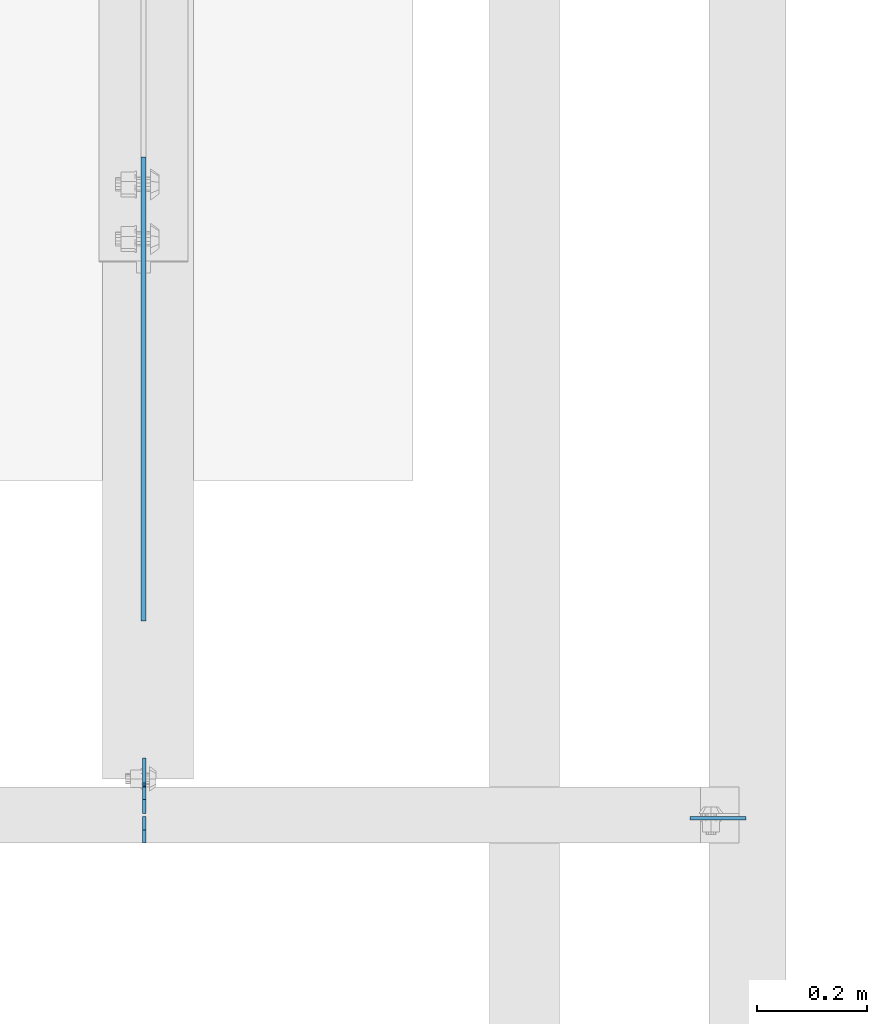
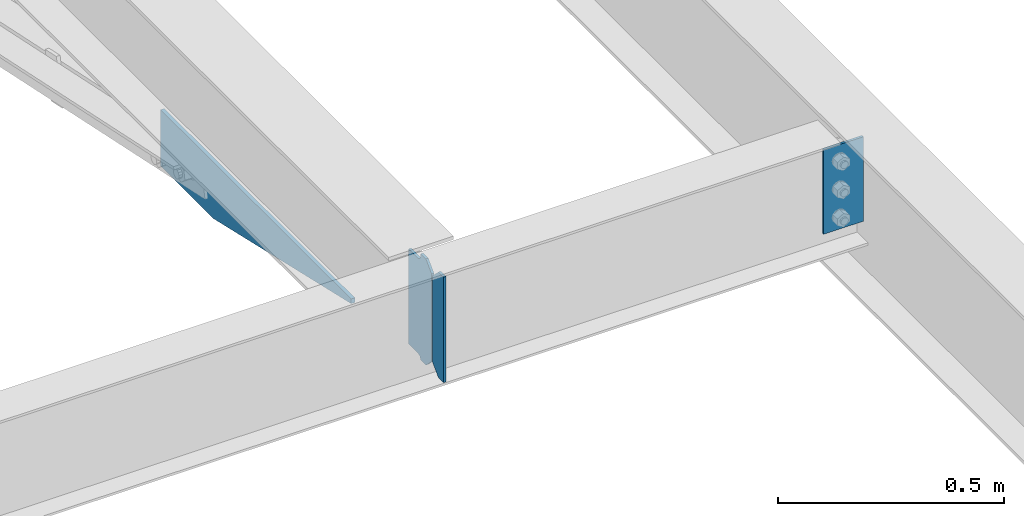
# One storey, part 1618 of 1763: 4 plates, 3 elements without a shape of their own.
"""IFC2X3 building model written with IfcOpenShell, lengths in millimetres."""

from ifc_helpers import new_model, si_unit, frame, origin_with_axes, place, context, subcontext, project, spatial, faceted_brep, material, type_object, element, aggregate, save


model = new_model("IFC2X3")

# Units and contexts
model_context = context("Model", 3, precision=1e-05, world=origin_with_axes())
body_context = subcontext(model_context, "Body", "Model", "MODEL_VIEW")
ifc_project = project(units=[si_unit("LENGTHUNIT", "METRE", prefix="MILLI"), si_unit("AREAUNIT", "SQUARE_METRE"), si_unit("VOLUMEUNIT", "CUBIC_METRE"), si_unit("MASSUNIT", "GRAM", prefix="KILO"), si_unit("TIMEUNIT", "SECOND"), si_unit("PLANEANGLEUNIT", "RADIAN"), si_unit("SOLIDANGLEUNIT", "STERADIAN"), si_unit("THERMODYNAMICTEMPERATUREUNIT", "DEGREE_CELSIUS"), si_unit("LUMINOUSINTENSITYUNIT", "LUMEN")], contexts=[model_context])

# Site, building, storey
site_placement = place(None, origin_with_axes())
site = spatial("IfcSite", under=ifc_project, at=site_placement, CompositionType="ELEMENT")
building_placement = place(site_placement, origin_with_axes())
building = spatial("IfcBuilding", under=site, at=building_placement, Name="Undefined", CompositionType="ELEMENT")
storey_placement = place(building_placement, origin_with_axes())
storey = spatial("IfcBuildingStorey", under=building, at=storey_placement, Name="Undefined", CompositionType="ELEMENT", Elevation=0.0)

# Assembly, plate
assembly_1_placement = place(storey_placement, origin_with_axes())
assembly_1 = element("IfcElementAssembly", 1, at=assembly_1_placement, inside=storey, Name="BEAM", AssemblyPlace="NOTDEFINED", PredefinedType="RIGID_FRAME")
ifc_material = material(Name="STEEL/A36")
plate_type_1 = type_object("IfcPlateType", PredefinedType="NOTDEFINED")
plate_1_placement = place(assembly_1_placement, frame((-60256.1747736984, 50880.5595338104, 4883.15), z_axis=(0.0, -1.0, 0.0), x_axis=(0.0, 0.0, -1.0)))
plate_1 = element("IfcPlate", 2, at=plate_1_placement, type_object=plate_type_1, material=ifc_material, Name="PLATE", context=body_context, shape_type="Brep", body=[
    faceted_brep([(0.0, -4.76249999999982, 0.0), (0.0, -4.76249999999709, 844.603210449219), (0.0, 4.76249999999709, 844.603210449219), (0.0, 4.76249999999982, 0.0), (12.6999998092651, -4.76249999999709, 844.603210449219), (12.6999998092651, 4.76249999999709, 844.603210449219), (152.399993896484, -4.76249999999709, 235.00325012207), (152.399993896484, 4.76249999999709, 235.00325012207), (152.400009155272, -4.76249999948777, 5.45696821063757e-12), (152.400009155273, 4.76250000051368, 3.63797880709171e-12)], [[[0, 1, 2, 3]], [[1, 4, 5, 2]], [[4, 6, 7, 5]], [[6, 8, 9, 7]], [[8, 0, 3, 9]], [[5, 7, 9, 3, 2]], [[8, 6, 4, 1, 0]]]),
])
aggregate(assembly_1, [plate_1])

assembly_2_placement = place(storey_placement, origin_with_axes())
assembly_2 = element("IfcElementAssembly", 3, at=assembly_2_placement, inside=storey, Name="BEAM", AssemblyPlace="NOTDEFINED", PredefinedType="RIGID_FRAME")
plate_type_2 = type_object("IfcPlateType", PredefinedType="NOTDEFINED")
plate_2_placement = place(assembly_2_placement, frame((-60254.587273746, 49684.78125, 4900.6125), z_axis=(0.0, 0.0, 1.0), x_axis=(0.0, 1.0, 0.0)))
plate_2 = element("IfcPlate", 4, at=plate_2_placement, type_object=plate_type_2, material=ifc_material, Name="PLATE", context=body_context, shape_type="Brep", body=[
    faceted_brep([(48.7345236062902, -3.17500000000291, 0.0), (48.7345236062902, 3.17500000000291, 0.0), (49.3854800386544, 3.17500000000291, 3.27257877585271), (49.3854800386544, -3.17500000000291, 3.27257877585271), (52.1384942519726, 3.17500000000291, 7.39275539271512), (52.1384942519726, -3.17500000000291, 7.39275539271512), (56.2586711318072, 3.17500000000291, 10.1457692124714), (56.2586711318072, -3.17500000000291, 10.1457692124714), (61.1187510223899, 3.17500000000291, 11.1124987868779), (61.1187510223899, -3.17500000000291, 11.1124987868779), (101.599998474121, -3.17500000000291, 11.1124949200548), (101.599998474121, 3.17500000000291, 11.1124949200548), (25.3999996184939, -3.17499999996653, 1.2732925824821e-11), (0.0, -3.17499999987194, 25.4000000001051), (0.0, 3.17500000014843, 25.4000000001197), (25.3999996185303, 3.17499995230901, 0.0), (0.0, -3.17500000000291, 261.937494277954), (0.0, 3.17500000000291, 261.937494277954), (25.3999996185303, -3.17500000000291, 287.337493896484), (25.3999996185303, 3.17500000000291, 287.337493896484), (48.4187500000044, -3.17500000000291, 287.337493896484), (48.4187500000044, 3.17500000000291, 287.337493896484), (48.4187500000044, -3.17500000000291, 280.987500572204), (48.4187500000044, 3.17500000000291, 280.987500572204), (49.3854799225956, -3.17500000000291, 276.127421054159), (49.3854799225956, 3.17500000000291, 276.127421054159), (52.1384938230694, -3.17500000000291, 272.007244586005), (52.1384938230694, 3.17500000000291, 272.007244586005), (56.2586702912231, -3.17500000000291, 269.254230685527), (56.2586702912231, 3.17500000000291, 269.254230685527), (61.1187498092695, -3.17500000000291, 268.287500762939), (61.1187498092695, 3.17500000000291, 268.287500762939), (101.599998474121, -3.17500000000291, 268.287500762939), (101.599998474121, 3.17500000000291, 268.287500762939)], [[[0, 1, 2, 3]], [[3, 2, 4, 5]], [[5, 4, 6, 7]], [[7, 6, 8, 9]], [[10, 9, 8, 11]], [[12, 13, 14, 15]], [[13, 16, 17, 14]], [[16, 18, 19, 17]], [[19, 18, 20, 21]], [[20, 22, 23, 21]], [[24, 25, 23, 22]], [[26, 27, 25, 24]], [[28, 29, 27, 26]], [[30, 31, 29, 28]], [[32, 33, 31, 30]], [[33, 32, 10, 11]], [[6, 4, 2, 1, 15, 14, 17, 19, 21, 23, 25, 27, 29, 31, 33, 11, 8]], [[12, 15, 1, 0]], [[32, 30, 28, 26, 24, 22, 20, 18, 16, 13, 12, 0, 3, 5, 7, 9, 10]]]),
])

assembly_3_placement = place(storey_placement, origin_with_axes())
assembly_3 = element("IfcElementAssembly", 5, at=assembly_3_placement, inside=storey, Name="BEAM", AssemblyPlace="NOTDEFINED", PredefinedType="RIGID_FRAME")
plate_3_placement = place(assembly_3_placement, frame((-59159.2122736984, 49676.84375, 5156.2), z_axis=(-1.0, 0.0, 0.0), x_axis=(0.0, 0.0, -1.0)))
plate_3 = element("IfcPlate", 6, at=plate_3_placement, type_object=plate_type_2, material=ifc_material, Name="PLATE", context=body_context, shape_type="Brep", body=[
    faceted_brep([(1.81898940354586e-12, -3.17500000000291, 0.0), (0.0, -3.17499999999927, 101.599998474121), (0.0, 3.17499999999927, 101.599998474121), (-1.81898940354586e-12, 3.17499999997381, 0.0), (228.600006103516, -3.17499999999927, 101.599998474121), (228.600006103516, 3.17499999999927, 101.599998474121), (228.600006103516, -3.17500000001019, -7.27595761418343e-12), (228.600006103516, 3.17499999999563, -7.27595761418343e-12)], [[[0, 1, 2, 3]], [[1, 4, 5, 2]], [[4, 6, 7, 5]], [[6, 0, 3, 7]], [[5, 7, 3, 2]], [[6, 4, 1, 0]]]),
])
aggregate(assembly_3, [plate_3])

# Plate
plate_type_3 = type_object("IfcPlateType", PredefinedType="NOTDEFINED")
plate_4_placement = place(assembly_2_placement, frame((-60254.587273746, 49680.01875, 4900.6125), z_axis=(0.0, 0.0, 1.0), x_axis=(0.0, -1.0, 0.0)))
plate_4 = element("IfcPlate", 7, at=plate_4_placement, type_object=plate_type_3, material=ifc_material, Name="PLATE", context=body_context, shape_type="Brep", body=[
    faceted_brep([(0.0, -3.17499999987194, 25.4000000001051), (0.0, -3.17500000000291, 260.35000038147), (0.0, 3.17500000000291, 260.35000038147), (0.0, 3.17500000014843, 25.4000000001197), (25.3999996185303, -3.17500000000291, 285.75), (25.3999996185303, 3.17500000000291, 285.75), (48.4187507629395, -3.17500000000291, 285.75), (48.4187507629395, 3.17500000000291, 285.75), (48.4187507629395, -3.17500000000291, 0.0), (48.4187507629395, 3.17500000000291, 0.0), (25.3999996184939, -3.17499999996653, 1.2732925824821e-11), (25.3999996185303, 3.17499995230901, 0.0)], [[[0, 1, 2, 3]], [[1, 4, 5, 2]], [[4, 6, 7, 5]], [[6, 8, 9, 7]], [[8, 10, 11, 9]], [[10, 0, 3, 11]], [[5, 7, 9, 11, 3, 2]], [[10, 8, 6, 4, 1, 0]]]),
])

aggregate(assembly_2, [plate_4, plate_2])

save(model, "model.ifc")
